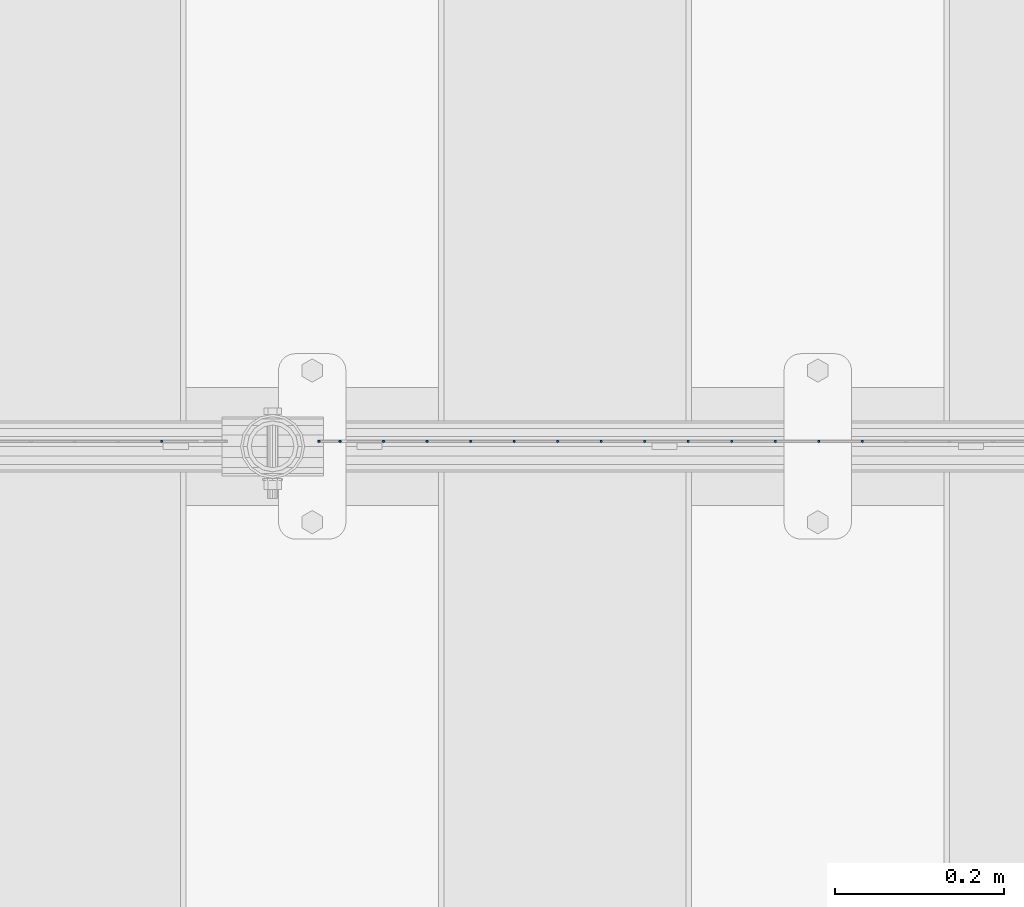
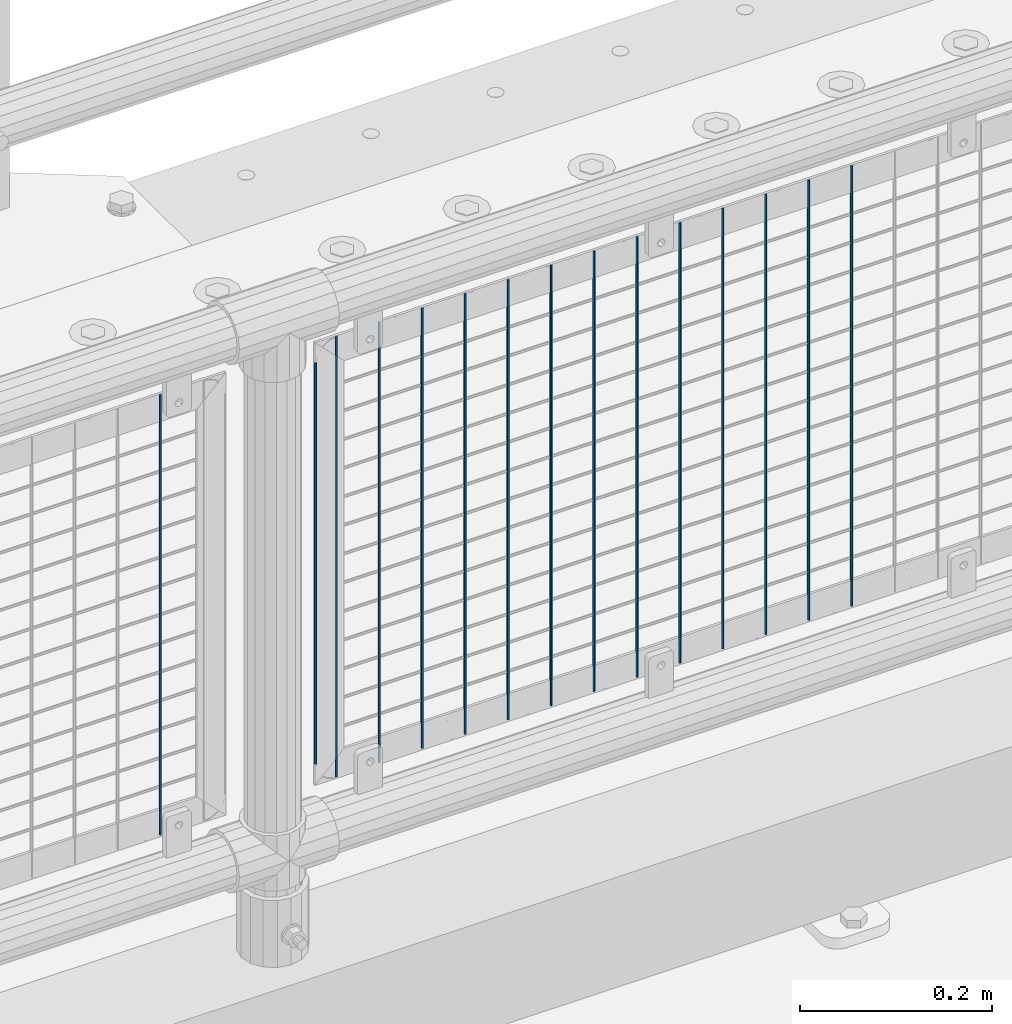
# One storey, part 83 of 240: 15 columns.
"""IFC2X3 building model written with IfcOpenShell, lengths in millimetres."""

import ifcopenshell
import ifcopenshell.guid

model = None  # the IFC model being written
_history = None  # IfcOwnerHistory: only IFC2X3 demands one
_inside = {}  # id of a spatial element -> (the spatial element, [elements in it])
_under = {}  # id of a project, library or spatial element -> (it, [spatial elements below it])
_declared = {}  # id of a project -> (the project, [libraries it declares])
_typed = {}  # id of a type object -> (the type object, [elements of that type])
_made_of = {}  # id of a material, layer set ... -> (it, [elements and type objects made of it])


def new_model(schema):
    """Start an empty IFC model of exactly this schema.

    Asked for "IFC4X3", IfcOpenShell would pick the latest addendum, in which some entities
    have other attributes; the version numbers below select the first issue.
    IFC2X3 requires an IfcOwnerHistory on every rooted entity: one is made here for all.
    """
    global model, _history
    if schema == "IFC4X3":
        model = ifcopenshell.file(schema_version=(4, 3, 0, 0))
    else:
        model = ifcopenshell.file(schema=schema)
    _inside.clear()
    _under.clear()
    _declared.clear()
    _typed.clear()
    _made_of.clear()
    _history = None
    if model.schema == "IFC2X3":
        org = make("IfcOrganization", Name="unknown")
        user = make(
            "IfcPersonAndOrganization",
            ThePerson=make("IfcPerson", FamilyName="unknown"),
            TheOrganization=org,
        )
        app = make(
            "IfcApplication",
            ApplicationDeveloper=org,
            Version="unknown",
            ApplicationFullName="unknown",
            ApplicationIdentifier="unknown",
        )
        _history = make(
            "IfcOwnerHistory",
            OwningUser=user,
            OwningApplication=app,
            ChangeAction="ADDED",
            CreationDate=0,
        )
    return model


def make(cls, **values):
    """One entity of the class cls with the attributes given. An attribute that is None is left unset."""
    return model.create_entity(
        cls, **{name: value for name, value in values.items() if value is not None}
    )


def rooted(cls, **values):
    """An entity with a GlobalId (a new one), such as an element, a storey or a relation."""
    return make(cls, GlobalId=ifcopenshell.guid.new(), OwnerHistory=_history, **values)


def si_unit(unit_type, name, prefix=None):
    """IfcSIUnit, for example si_unit("LENGTHUNIT", "METRE", prefix="MILLI")."""
    return make("IfcSIUnit", UnitType=unit_type, Prefix=prefix, Name=name)


def assignment(units):
    """IfcUnitAssignment: the units of a project."""
    return None if units is None else make("IfcUnitAssignment", Units=units)


def point(xyz):
    """IfcCartesianPoint."""
    return None if xyz is None else make("IfcCartesianPoint", Coordinates=xyz)


def direction(xyz):
    """IfcDirection."""
    return None if xyz is None else make("IfcDirection", DirectionRatios=xyz)


def frame(location, z_axis=None, x_axis=None):
    """IfcAxis2Placement3D, a coordinate frame: its origin and axes. An axis left out is left unset."""
    return make(
        "IfcAxis2Placement3D",
        Location=point(location),
        Axis=direction(z_axis),
        RefDirection=direction(x_axis),
    )


def origin_with_axes():
    """The frame at (0, 0, 0) with the z axis (0, 0, 1) and the x axis (1, 0, 0) written out."""
    return frame((0.0, 0.0, 0.0), z_axis=(0.0, 0.0, 1.0), x_axis=(1.0, 0.0, 0.0))


def place(relative_to, where):
    """IfcLocalPlacement: puts the frame where relative to a parent placement (None: the world)."""
    return make(
        "IfcLocalPlacement", PlacementRelTo=relative_to, RelativePlacement=where
    )


def context(
    kind, dimensions, precision=None, world=None, true_north=None, identifier=None
):
    """IfcGeometricRepresentationContext, for example the 3D "Model" context."""
    return make(
        "IfcGeometricRepresentationContext",
        ContextIdentifier=identifier,
        ContextType=kind,
        CoordinateSpaceDimension=dimensions,
        Precision=precision,
        WorldCoordinateSystem=world,
        TrueNorth=true_north,
    )


def subcontext(parent, identifier, kind, view, scale=None):
    """IfcGeometricRepresentationSubContext, for example "Body" below "Model"."""
    return make(
        "IfcGeometricRepresentationSubContext",
        ContextIdentifier=identifier,
        ContextType=kind,
        ParentContext=parent,
        TargetScale=scale,
        TargetView=view,
    )


def project(units=None, contexts=None):
    """IfcProject with its units and contexts."""
    return rooted(
        "IfcProject",
        Name="project",
        RepresentationContexts=contexts,
        UnitsInContext=assignment(units),
    )


def spatial(cls, under=None, at=None, **own):
    """A site, building, storey or space (cls), placed at a placement, below another one or the project."""
    s = rooted(cls, ObjectPlacement=at, **own)
    if under is not None:
        _under.setdefault(under.id(), (under, []))[1].append(s)
    return s


def faces_of(points, faces, orient=None, outer=None):
    """IfcFace entities. A face is a list of loops; a loop is a list of indices into points, from 0.

    orient and outer hold one flag for each loop. By default every Orientation is true, the
    first loop of a face is its IfcFaceOuterBound and the others are IfcFaceBound.
    """
    made = []
    for i, loops in enumerate(faces):
        bounds = []
        for j, loop in enumerate(loops):
            is_outer = j == 0 if outer is None else outer[i][j]
            bounds.append(
                make(
                    "IfcFaceOuterBound" if is_outer else "IfcFaceBound",
                    Bound=make("IfcPolyLoop", Polygon=[points[k] for k in loop]),
                    Orientation=True if orient is None else orient[i][j],
                )
            )
        made.append(make("IfcFace", Bounds=bounds))
    return made


def faceted_brep(points, faces, orient=None, outer=None, voids=None):
    """IfcFacetedBrep: a solid bounded by flat faces; with voids (closed shells), ...WithVoids."""
    shared = [point(p) for p in points]
    hull = make("IfcClosedShell", CfsFaces=faces_of(shared, faces, orient, outer))
    if voids is None:
        return make("IfcFacetedBrep", Outer=hull)
    return make(
        "IfcFacetedBrepWithVoids",
        Outer=hull,
        Voids=[
            make(cls, CfsFaces=faces_of(shared, fs, o, b)) for cls, fs, o, b in voids
        ],
    )


def shape(context_of_items, identifier, shape_type, items):
    """IfcShapeRepresentation: the items that make up one representation, for example the "Body"."""
    return make(
        "IfcShapeRepresentation",
        ContextOfItems=context_of_items,
        RepresentationIdentifier=identifier,
        RepresentationType=shape_type,
        Items=items,
    )


def material(Name=None, Category=None):
    """IfcMaterial."""
    return make("IfcMaterial", Name=Name, Category=Category)


def made_of(thing, what):
    """Note that an element or type object is made of a material, layer set ...; save() writes the relation."""
    if what is not None:
        _made_of.setdefault(what.id(), (what, []))[1].append(thing)
    return thing


def type_object(cls, material=None, **own):
    """A type object (cls), such as IfcWallType, which elements share."""
    return made_of(rooted(cls, **own), material)


def element(
    cls,
    number,
    at=None,
    inside=None,
    cuts=None,
    type_object=None,
    material=None,
    context=None,
    identifier="Body",
    shape_type=None,
    held_by="IfcProductDefinitionShape",
    body=None,
    shapes=None,
    **own,
):
    """One element of the class cls, such as IfcWall. Its Tag is "e" and its number.

    at: its placement. inside: the storey or other place that contains it. cuts: it is an
    opening in that element (IfcRelVoidsElement). A single representation is given by context,
    identifier, shape_type and body (its items); several are given by shapes. held_by: the class
    of the entity that holds the representations. save() writes the other relations.
    """
    e = rooted(cls, Tag="e%d" % number, ObjectPlacement=at, **own)
    if body is not None:
        shapes = [shape(context, identifier, shape_type, body)]
    if shapes is not None:
        e.Representation = make(held_by, Representations=shapes)
    if inside is not None:
        _inside.setdefault(inside.id(), (inside, []))[1].append(e)
    if cuts is not None:
        rooted(
            "IfcRelVoidsElement", RelatingBuildingElement=cuts, RelatedOpeningElement=e
        )
    if type_object is not None:
        _typed.setdefault(type_object.id(), (type_object, []))[1].append(e)
    return made_of(e, material)


def aggregate(whole, parts):
    """IfcRelAggregates: a whole, such as a stair, and the parts it consists of."""
    return rooted("IfcRelAggregates", RelatingObject=whole, RelatedObjects=parts)


def save(model, path):
    """Write the relations noted so far, then the file.

    IfcRelAggregates (storeys below a building ...), IfcRelContainedInSpatialStructure (elements
    in a storey), IfcRelDefinesByType, IfcRelAssociatesMaterial and IfcRelDeclares: one each for
    every whole, place, type object, material and project.
    """
    for whole, parts in _under.values():
        aggregate(whole, parts)
    for where, things in _inside.values():
        rooted(
            "IfcRelContainedInSpatialStructure",
            RelatedElements=things,
            RelatingStructure=where,
        )
    for kind, things in _typed.values():
        rooted("IfcRelDefinesByType", RelatedObjects=things, RelatingType=kind)
    for what, things in _made_of.values():
        rooted("IfcRelAssociatesMaterial", RelatedObjects=things, RelatingMaterial=what)
    for by, libraries in _declared.values():
        rooted("IfcRelDeclares", RelatingContext=by, RelatedDefinitions=libraries)
    model.write(path)


model = new_model("IFC2X3")

# Units and contexts
model_context = context("Model", 3, precision=1e-05, world=origin_with_axes())
body_context = subcontext(model_context, "Body", "Model", "MODEL_VIEW")
ifc_project = project(units=[si_unit("LENGTHUNIT", "METRE", prefix="MILLI"), si_unit("AREAUNIT", "SQUARE_METRE"), si_unit("VOLUMEUNIT", "CUBIC_METRE"), si_unit("MASSUNIT", "GRAM", prefix="KILO"), si_unit("TIMEUNIT", "SECOND"), si_unit("PLANEANGLEUNIT", "RADIAN"), si_unit("SOLIDANGLEUNIT", "STERADIAN"), si_unit("THERMODYNAMICTEMPERATUREUNIT", "DEGREE_CELSIUS"), si_unit("LUMINOUSINTENSITYUNIT", "LUMEN")], contexts=[model_context])

# Site, building, storey
site_placement = place(None, origin_with_axes())
site = spatial("IfcSite", under=ifc_project, at=site_placement, CompositionType="ELEMENT")
building_placement = place(site_placement, origin_with_axes())
building = spatial("IfcBuilding", under=site, at=building_placement, Name="Standard", CompositionType="ELEMENT")
storey_placement = place(building_placement, origin_with_axes())
storey = spatial("IfcBuildingStorey", under=building, at=storey_placement, Name="Undefined", CompositionType="ELEMENT", Elevation=0.0)

# Columns
ifc_material = material(Name="Misc_Undefined")
column_type = type_object("IfcColumnType", Name="D3", PredefinedType="NOTDEFINED")
for number, where, z_axis, x_axis in (
    (1, (50402.86, 34670.5, 353.020000000001), (-1.0, 0.0, 0.0), (0.0, 0.0, 1.0)),
    (2, (50351.205, 34670.5, 353.020000000001), (-1.0, 0.0, 0.0), (0.0, 0.0, 1.0)),
    (3, (50299.55, 34670.5, 353.020000000001), (-1.0, 0.0, 0.0), (0.0, 0.0, 1.0)),
    (4, (50247.895, 34670.5, 353.020000000001), (-1.0, 0.0, 0.0), (0.0, 0.0, 1.0)),
    (5, (50196.24, 34670.5, 353.020000000001), (-1.0, 0.0, 0.0), (0.0, 0.0, 1.0)),
    (6, (50144.585, 34670.5, 353.020000000001), (-1.0, 0.0, 0.0), (0.0, 0.0, 1.0)),
    (7, (50092.93, 34670.5, 353.020000000001), (-1.0, 0.0, 0.0), (0.0, 0.0, 1.0)),
    (8, (50041.275, 34670.5, 353.020000000001), (-1.0, 0.0, 0.0), (0.0, 0.0, 1.0)),
    (9, (49989.62, 34670.5, 353.020000000001), (-1.0, 0.0, 0.0), (0.0, 0.0, 1.0)),
    (10, (49937.965, 34670.5, 353.020000000001), (-1.0, 0.0, 0.0), (0.0, 0.0, 1.0)),
    (11, (49886.31, 34670.5, 353.020000000001), (-1.0, 0.0, 0.0), (0.0, 0.0, 1.0)),
    (12, (49834.655, 34670.5, 353.020000000001), (-1.0, 0.0, 0.0), (0.0, 0.0, 1.0)),
):
    element("IfcColumn", number, at=place(storey_placement, frame(where, z_axis=z_axis, x_axis=x_axis)), inside=storey, type_object=column_type, material=ifc_material, ObjectType="D3", context=body_context, shape_type="Brep", body=[
        faceted_brep([(-7.27595761418343e-12, -1.49999999999272, 0.0), (-7.27595761418343e-12, -0.749999999992724, -1.29903810567669), (560.0, -0.75, -1.29903810567339), (560.0, -1.5, 0.0), (0.0, 0.750000000007276, -1.29903810567669), (560.0, 0.75, -1.29903810567339), (0.0, 1.50000000000728, 0.0), (560.0, 1.5, 0.0), (0.0, 0.750000000007276, 1.29903810567669), (560.0, 0.75, 1.29903810567339), (-7.27595761418343e-12, -0.749999999992724, 1.29903810567669), (560.0, -0.75, 1.29903810567339)], [[[0, 1, 2, 3]], [[1, 4, 5, 2]], [[4, 6, 7, 5]], [[6, 8, 9, 7]], [[8, 10, 11, 9]], [[10, 0, 3, 11]], [[5, 7, 9, 11, 3, 2]], [[10, 8, 6, 4, 1, 0]]]),
    ])
column_placement = place(storey_placement, frame((49758.0, 34670.5, 378.020000000001), z_axis=(-1.0, 0.0, 0.0), x_axis=(0.0, 0.0, 1.0)))
element("IfcColumn", 13, at=column_placement, inside=storey, type_object=column_type, material=ifc_material, ObjectType="D3", context=body_context, shape_type="Brep", body=[
    faceted_brep([(-7.27595761418343e-12, -1.49999999999272, 0.0), (-7.27595761418343e-12, -0.749999999992724, -1.29903810567669), (510.0, -0.75, -1.29903810567339), (510.0, -1.5, 0.0), (0.0, 0.750000000007276, -1.29903810567669), (510.0, 0.75, -1.29903810567339), (0.0, 1.50000000000728, 0.0), (510.0, 1.5, 0.0), (0.0, 0.750000000007276, 1.29903810567669), (510.0, 0.75, 1.29903810567339), (-7.27595761418343e-12, -0.749999999992724, 1.29903810567669), (510.0, -0.75, 1.29903810567339)], [[[0, 1, 2, 3]], [[1, 4, 5, 2]], [[4, 6, 7, 5]], [[6, 8, 9, 7]], [[8, 10, 11, 9]], [[10, 0, 3, 11]], [[5, 7, 9, 11, 3, 2]], [[10, 8, 6, 4, 1, 0]]]),
])
for number, where, z_axis, x_axis in (
    (14, (49783.0, 34670.5, 353.020000000001), (-1.0, 0.0, 0.0), (0.0, 0.0, 1.0)),
    (15, (49571.34, 34670.5, 353.02), (-1.0, 0.0, 0.0), (0.0, 0.0, 1.0)),
):
    element("IfcColumn", number, at=place(storey_placement, frame(where, z_axis=z_axis, x_axis=x_axis)), inside=storey, type_object=column_type, material=ifc_material, ObjectType="D3", context=body_context, shape_type="Brep", body=[
        faceted_brep([(-7.27595761418343e-12, -1.49999999999272, 0.0), (-7.27595761418343e-12, -0.749999999992724, -1.29903810567669), (560.0, -0.75, -1.29903810567339), (560.0, -1.5, 0.0), (0.0, 0.750000000007276, -1.29903810567669), (560.0, 0.75, -1.29903810567339), (0.0, 1.50000000000728, 0.0), (560.0, 1.5, 0.0), (0.0, 0.750000000007276, 1.29903810567669), (560.0, 0.75, 1.29903810567339), (-7.27595761418343e-12, -0.749999999992724, 1.29903810567669), (560.0, -0.75, 1.29903810567339)], [[[0, 1, 2, 3]], [[1, 4, 5, 2]], [[4, 6, 7, 5]], [[6, 8, 9, 7]], [[8, 10, 11, 9]], [[10, 0, 3, 11]], [[5, 7, 9, 11, 3, 2]], [[10, 8, 6, 4, 1, 0]]]),
    ])

save(model, "model.ifc")
